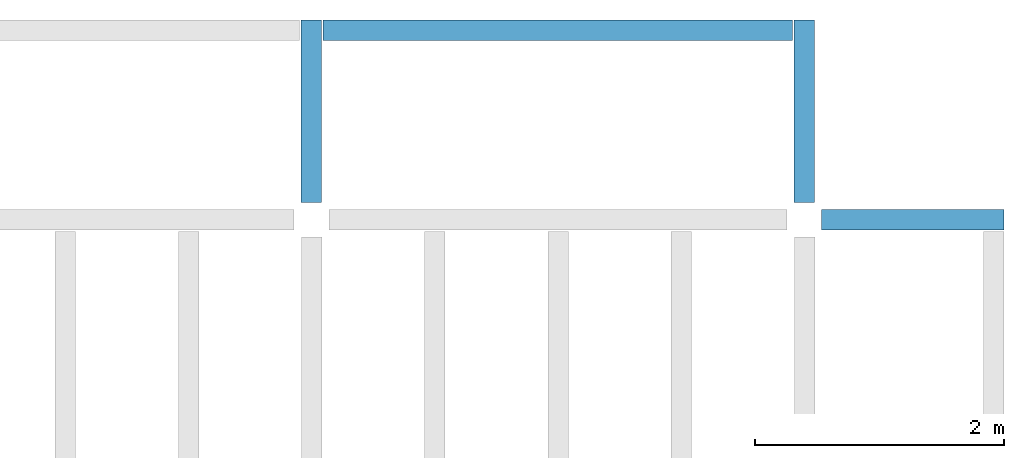
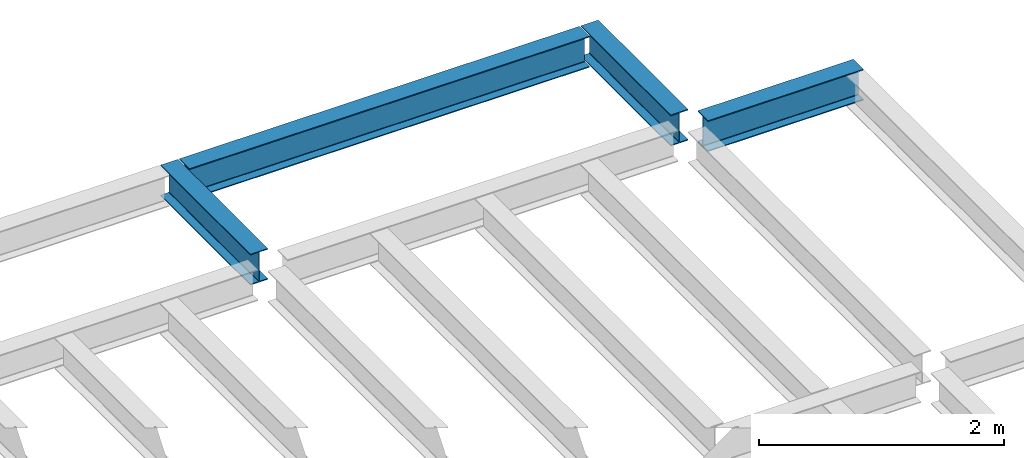
# One storey, part 3 of 3: 4 beams.
"""IFC4 building model written with IfcOpenShell, lengths in feet."""

from ifc_helpers import new_model, entity, si_unit, converted_unit, derived_unit, direction, frame, origin, place, context, subcontext, project, spatial, line, arc, indexed_curve, outline, extrude, source, transform, mapped, material, type_object, type_shapes, element, save


model = new_model("IFC4")

# Units and contexts
model_context = context("Model", 3, precision=0.0001, world=origin(), true_north=direction((6.123233995736766e-17, 1.0)))
plan_context = context("Plan", 3, precision=0.0001, world=origin(), true_north=direction((6.123233995736766e-17, 1.0)))
body_context = subcontext(model_context, "Body", "Model", "MODEL_VIEW")
ifc_project = project(units=[converted_unit("LENGTHUNIT", "FOOT", entity("IfcLengthMeasure", 0.3048), si_unit("LENGTHUNIT", "METRE"), dimensions=[1, 0, 0, 0, 0, 0, 0]), converted_unit("AREAUNIT", "SQUARE FOOT", entity("IfcAreaMeasure", 0.09290304), si_unit("AREAUNIT", "SQUARE_METRE"), dimensions=[2, 0, 0, 0, 0, 0, 0]), converted_unit("PLANEANGLEUNIT", "DEGREE", entity("IfcPlaneAngleMeasure", 0.017453292519943278), si_unit("PLANEANGLEUNIT", "RADIAN"), dimensions=[0, 0, 0, 0, 0, 0, 0]), converted_unit("VOLUMEUNIT", "CUBIC FOOT", entity("IfcVolumeMeasure", 0.028316846592000004), si_unit("VOLUMEUNIT", "CUBIC_METRE"), dimensions=[3, 0, 0, 0, 0, 0, 0]), si_unit("PRESSUREUNIT", "PASCAL"), derived_unit("MASSDENSITYUNIT", [(si_unit("MASSUNIT", "GRAM", prefix="KILO"), 1), (si_unit("LENGTHUNIT", "METRE"), -3)]), derived_unit("VAPORPERMEABILITYUNIT", [(si_unit("LENGTHUNIT", "METRE"), -1), (si_unit("TIMEUNIT", "SECOND"), 1)]), derived_unit("USERDEFINED", [(si_unit("MASSUNIT", "GRAM", prefix="KILO"), 1), (si_unit("LENGTHUNIT", "METRE"), 3), (si_unit("TIMEUNIT", "SECOND"), -3), (si_unit("ELECTRICCURRENTUNIT", "AMPERE"), -2)]), derived_unit("MODULUSOFELASTICITYUNIT", [(si_unit("MASSUNIT", "GRAM", prefix="KILO"), 1), (si_unit("LENGTHUNIT", "METRE"), -1), (si_unit("TIMEUNIT", "SECOND"), -2)]), derived_unit("THERMALEXPANSIONCOEFFICIENTUNIT", [(si_unit("THERMODYNAMICTEMPERATUREUNIT", "KELVIN"), -1)]), derived_unit("SPECIFICHEATCAPACITYUNIT", [(si_unit("TIMEUNIT", "SECOND"), -2), (si_unit("THERMODYNAMICTEMPERATUREUNIT", "KELVIN"), -1), (si_unit("LENGTHUNIT", "METRE"), 2)]), derived_unit("THERMALCONDUCTANCEUNIT", [(si_unit("MASSUNIT", "GRAM", prefix="KILO"), 1), (si_unit("TIMEUNIT", "SECOND"), -3), (si_unit("THERMODYNAMICTEMPERATUREUNIT", "KELVIN"), -1), (si_unit("LENGTHUNIT", "METRE"), 1)])], contexts=[model_context, plan_context])

# Site, building, storey
site_placement = place(None, origin())
site = spatial("IfcSite", under=ifc_project, at=site_placement, CompositionType="ELEMENT")
building_placement = place(site_placement, origin())
building = spatial("IfcBuilding", under=site, at=building_placement, CompositionType="ELEMENT")
storey_placement = place(building_placement, frame((0.0, 0.0, 129.875)))
storey = spatial("IfcBuildingStorey", under=building, at=storey_placement, Name="STR 14", CompositionType="ELEMENT", Elevation=129.875)

# Beams
ifc_material = material(Name="Steel ASTM A992", Category="Metal")
beam_type_1 = type_object("IfcBeamType", Name="W12X26", PredefinedType="JOIST", material=ifc_material)
shared_shape_1 = source(origin(), body_context, "Body", "SweptSolid", [
    extrude(outline(indexed_curve([(0.47666666666666574, -0.2704166666666672), (0.5083333333333351, -0.2704166666666672), (0.5083333333333351, 0.27041666666666686), (0.47666666666666574, 0.27041666666666686), (0.47666666666666574, 0.03458333333333307), (0.46934433619632937, 0.016905663803669473), (0.4516666666666659, 0.00958333333333318), (-0.45166666666666705, 0.00958333333333318), (-0.4693443361963307, 0.01690566380366946), (-0.4766666666666671, 0.03458333333333323), (-0.4766666666666671, 0.27041666666666686), (-0.5083333333333312, 0.27041666666666686), (-0.5083333333333312, -0.27041666666666553), (-0.4766666666666671, -0.27041666666666553), (-0.47666666666666707, -0.034583333333333535), (-0.46934433619633054, -0.016905663803669885), (-0.45166666666666694, -0.00958333333333376), (0.4516666666666658, -0.009583333333333756), (0.4693443361963295, -0.01690566380367015), (0.47666666666666574, -0.0345833333333337)], segments=[line(1, 2, 3, 4, 5), arc(5, 6, 7), line(7, 8), arc(8, 9, 10), line(10, 11, 12, 13, 14, 15), arc(15, 16, 17), line(17, 18), arc(18, 19, 20), line(20, 1)], self_intersect=False)), frame((-2.77041666666672, 0.0, 0.0), z_axis=(1.0, 0.0, 0.0), x_axis=(0.0, 0.0, -1.0)), (0.0, 0.0, 1.0), 4.812083333333389),
])
type_shapes(beam_type_1, [shared_shape_1])
beam_1_placement = place(storey_placement, frame((41.50000000000015, 39.0, -0.5083333333333258), z_axis=(0.0, 0.0, 1.0), x_axis=(-1.0, 0.0, 0.0)))
element("IfcBeam", 1, at=beam_1_placement, inside=storey, type_object=beam_type_1, material=ifc_material, Name="W12X26", ObjectType="W Shapes:W12X26", PredefinedType="JOIST", context=body_context, shape_type="MappedRepresentation", body=[
    mapped(shared_shape_1, transform((0.0, 0.0, 0.0), scale=1.0)),
])
beam_type_2 = type_object("IfcBeamType", Name="W12X26", PredefinedType="JOIST", material=ifc_material)
shared_shape_2 = source(origin(), body_context, "Body", "SweptSolid", [
    extrude(outline(indexed_curve([(-0.2704166666666623, -0.5083333333333258), (0.2704166666666694, -0.5083333333333258), (0.2704166666666694, -0.47666666666665947), (0.03458333333333741, -0.47666666666665947), (0.016905663803683524, -0.46934433619631477), (0.009583333333338828, -0.4516666666666538), (0.009583333333338828, 0.4516666666666822), (0.016905663803683524, 0.4693443361963432), (0.03458333333333741, 0.4766666666666879), (0.2704166666666694, 0.4766666666666879), (0.2704166666666694, 0.5083333333333542), (-0.2704166666666623, 0.5083333333333542), (-0.2704166666666623, 0.4766666666666879), (-0.0345833333333303, 0.4766666666666879), (-0.01690566380367642, 0.4693443361963432), (-0.009583333333331723, 0.4516666666666822), (-0.009583333333331723, -0.4516666666666538), (-0.01690566380367642, -0.46934433619631477), (-0.0345833333333303, -0.47666666666665947), (-0.2704166666666623, -0.47666666666665947)], segments=[line(1, 2, 3, 4), arc(4, 5, 6), line(6, 7), arc(7, 8, 9), line(9, 10, 11, 12, 13, 14), arc(14, 15, 16), line(16, 17), arc(17, 18, 19), line(19, 20, 1)], self_intersect=False)), frame((39.0, 44.270416666666286, 129.36666666666667), z_axis=(0.0, -1.0, 0.0), x_axis=(-1.0, 0.0, 0.0)), (0.0, 0.0, 1.0), 4.812083333333393),
])
type_shapes(beam_type_2, [shared_shape_2])
beam_2_placement = place(storey_placement, frame((0.0, 0.0, -129.875)))
element("IfcBeam", 2, at=beam_2_placement, inside=storey, type_object=beam_type_2, material=ifc_material, Name="W12X26", ObjectType="W Shapes:W12X26", PredefinedType="JOIST", context=body_context, shape_type="MappedRepresentation", body=[
    mapped(shared_shape_2, transform((0.0, 0.0, 0.0), scale=1.0)),
])
beam_type_3 = type_object("IfcBeamType", Name="W12X26", PredefinedType="JOIST", material=ifc_material)
shared_shape_3 = source(origin(), body_context, "Body", "SweptSolid", [
    extrude(outline(indexed_curve([(-0.2704166666666694, -0.5083333333333258), (0.27041666666666586, -0.5083333333333258), (0.2704166666666623, -0.47666666666665947), (0.034583333333333854, -0.47666666666663104), (0.01690566380367997, -0.46934433619631477), (0.009583333333335275, -0.4516666666666538), (0.009583333333335275, 0.4516666666666822), (0.01690566380367997, 0.4693443361963432), (0.034583333333333854, 0.4766666666666879), (0.2704166666666694, 0.4766666666666879), (0.27041666666666586, 0.5083333333333542), (-0.27041666666666586, 0.5083333333333542), (-0.27041666666666586, 0.4766666666666879), (-0.0345833333333303, 0.47666666666665947), (-0.01690566380367642, 0.4693443361963432), (-0.009583333333331723, 0.4516666666666822), (-0.009583333333331723, -0.4516666666666538), (-0.01690566380367642, -0.46934433619631477), (-0.034583333333333854, -0.47666666666665947), (-0.27041666666666586, -0.47666666666665947)], segments=[line(1, 2, 3, 4), arc(4, 5, 6), line(6, 7), arc(7, 8, 9), line(9, 10, 11, 12, 13, 14), arc(14, 15, 16), line(16, 17), arc(17, 18, 19), line(19, 20, 1)], self_intersect=False)), frame((26.0, 44.27041666666632, 129.36666666666667), z_axis=(0.0, -1.0, 0.0), x_axis=(-1.0, 0.0, 0.0)), (0.0, 0.0, 1.0), 4.812083333333393),
])
type_shapes(beam_type_3, [shared_shape_3])
beam_3_placement = place(storey_placement, frame((0.0, 0.0, -129.875)))
element("IfcBeam", 3, at=beam_3_placement, inside=storey, type_object=beam_type_3, material=ifc_material, Name="W12X26", ObjectType="W Shapes:W12X26", PredefinedType="JOIST", context=body_context, shape_type="MappedRepresentation", body=[
    mapped(shared_shape_3, transform((0.0, 0.0, 0.0), scale=1.0)),
])
beam_type_4 = type_object("IfcBeamType", Name="W12X26", PredefinedType="JOIST", material=ifc_material)
shared_shape_4 = source(origin(), body_context, "Body", "SweptSolid", [
    extrude(outline(indexed_curve([(-0.5083333333333258, -0.2704166666666694), (-0.47666666666665947, -0.2704166666666694), (-0.47666666666665947, -0.03458333333333741), (-0.46934433619631477, -0.016905663803683524), (-0.4516666666666538, -0.009583333333338828), (0.4516666666666822, -0.009583333333338828), (0.4693443361963432, -0.016905663803683524), (0.4766666666666879, -0.03458333333333741), (0.4766666666666879, -0.2704166666666694), (0.5083333333333542, -0.2704166666666694), (0.5083333333333542, 0.2704166666666623), (0.4766666666666879, 0.2704166666666623), (0.4766666666666879, 0.0345833333333303), (0.4693443361963432, 0.01690566380367642), (0.4516666666666822, 0.009583333333331723), (-0.4516666666666538, 0.009583333333331723), (-0.46934433619631477, 0.01690566380367642), (-0.47666666666665947, 0.0345833333333303), (-0.47666666666665947, 0.2704166666666623), (-0.5083333333333258, 0.2704166666666623)], segments=[line(1, 2, 3), arc(3, 4, 5), line(5, 6), arc(6, 7, 8), line(8, 9, 10, 11, 12, 13), arc(13, 14, 15), line(15, 16), arc(16, 17, 18), line(18, 19, 20, 1)], self_intersect=False)), frame((26.312083333333604, 44.0, 129.36666666666667), z_axis=(1.0, 0.0, 0.0), x_axis=(0.0, 0.0, -1.0)), (0.0, 0.0, 1.0), 12.375833333333079),
])
type_shapes(beam_type_4, [shared_shape_4])
beam_4_placement = place(storey_placement, frame((0.0, 0.0, -129.875)))
element("IfcBeam", 4, at=beam_4_placement, inside=storey, type_object=beam_type_4, material=ifc_material, Name="W Shapes:W12X26", ObjectType="W Shapes:W12X26", PredefinedType="JOIST", context=body_context, shape_type="MappedRepresentation", body=[
    mapped(shared_shape_4, transform((0.0, 0.0, 0.0), scale=1.0)),
])

save(model, "model.ifc")
